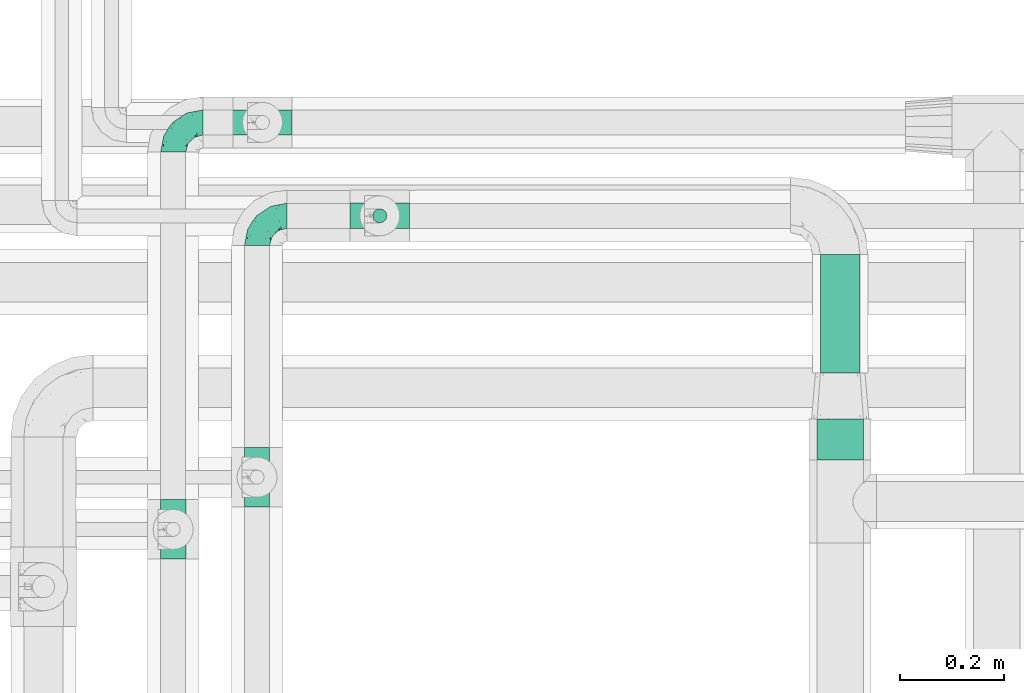
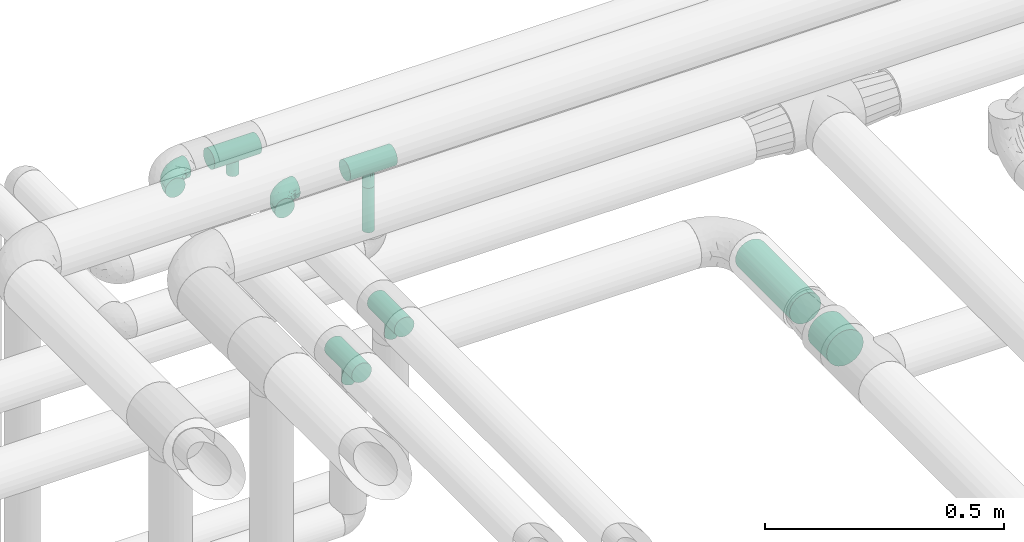
# One storey, part 652 of 827: 6 flow fittings, 3 flow segments.
"""IFC2X3 building model written with IfcOpenShell, lengths in millimetres."""

from ifc_helpers import new_model, entity, si_unit, converted_unit, derived_unit, direction, frame, origin, origin_2d_with_axis, place, context, subcontext, project, spatial, circle, extrude, faceted_brep, source, transform, mapped, material, type_object, type_shapes, element, save


model = new_model("IFC2X3")

# Units and contexts
model_context = context("Model", 3, precision=0.01, world=origin(), true_north=direction((6.12303176911189e-17, 1.0)))
body_context = subcontext(model_context, "Body", "Model", "MODEL_VIEW")
ifc_project = project(units=[si_unit("LENGTHUNIT", "METRE", prefix="MILLI"), si_unit("AREAUNIT", "SQUARE_METRE"), si_unit("VOLUMEUNIT", "CUBIC_METRE"), converted_unit("PLANEANGLEUNIT", "DEGREE", entity("IfcRatioMeasure", 0.0174532925199433), si_unit("PLANEANGLEUNIT", "RADIAN"), dimensions=[0, 0, 0, 0, 0, 0, 0]), si_unit("MASSUNIT", "GRAM", prefix="KILO"), derived_unit("MASSDENSITYUNIT", [(si_unit("MASSUNIT", "GRAM", prefix="KILO"), 1), (si_unit("LENGTHUNIT", "METRE"), -3)]), derived_unit("MOMENTOFINERTIAUNIT", [(si_unit("LENGTHUNIT", "METRE"), 4)]), si_unit("TIMEUNIT", "SECOND"), si_unit("FREQUENCYUNIT", "HERTZ"), si_unit("THERMODYNAMICTEMPERATUREUNIT", "DEGREE_CELSIUS"), derived_unit("THERMALTRANSMITTANCEUNIT", [(si_unit("MASSUNIT", "GRAM", prefix="KILO"), 1), (si_unit("THERMODYNAMICTEMPERATUREUNIT", "KELVIN"), -1), (si_unit("TIMEUNIT", "SECOND"), -3)]), derived_unit("VOLUMETRICFLOWRATEUNIT", [(si_unit("LENGTHUNIT", "METRE"), 3), (si_unit("TIMEUNIT", "SECOND"), -1)]), derived_unit("MASSFLOWRATEUNIT", [(si_unit("MASSUNIT", "GRAM", prefix="KILO"), 1), (si_unit("TIMEUNIT", "SECOND"), -1)]), derived_unit("ROTATIONALFREQUENCYUNIT", [(si_unit("TIMEUNIT", "SECOND"), -1)]), si_unit("ELECTRICCURRENTUNIT", "AMPERE"), si_unit("ELECTRICVOLTAGEUNIT", "VOLT"), si_unit("POWERUNIT", "WATT"), si_unit("FORCEUNIT", "NEWTON", prefix="KILO"), si_unit("ILLUMINANCEUNIT", "LUX"), si_unit("LUMINOUSFLUXUNIT", "LUMEN"), si_unit("LUMINOUSINTENSITYUNIT", "CANDELA"), derived_unit("USERDEFINED", [(si_unit("MASSUNIT", "GRAM", prefix="KILO"), -1), (si_unit("LENGTHUNIT", "METRE"), -2), (si_unit("TIMEUNIT", "SECOND"), 3), (si_unit("LUMINOUSFLUXUNIT", "LUMEN"), 1)]), derived_unit("LINEARVELOCITYUNIT", [(si_unit("LENGTHUNIT", "METRE"), 1), (si_unit("TIMEUNIT", "SECOND"), -1)]), si_unit("PRESSUREUNIT", "PASCAL"), derived_unit("USERDEFINED", [(si_unit("LENGTHUNIT", "METRE"), -2), (si_unit("MASSUNIT", "GRAM", prefix="KILO"), 1), (si_unit("TIMEUNIT", "SECOND"), -2)]), derived_unit("LINEARFORCEUNIT", [(si_unit("MASSUNIT", "GRAM", prefix="KILO"), 1), (si_unit("LENGTHUNIT", "METRE"), 1), (si_unit("TIMEUNIT", "SECOND"), -2), (si_unit("LENGTHUNIT", "METRE"), -1)]), derived_unit("PLANARFORCEUNIT", [(si_unit("MASSUNIT", "GRAM", prefix="KILO"), 1), (si_unit("LENGTHUNIT", "METRE"), 1), (si_unit("TIMEUNIT", "SECOND"), -2), (si_unit("LENGTHUNIT", "METRE"), -2)])], contexts=[model_context])

# Site, building, storey
site_placement = place(None, origin())
site = spatial("IfcSite", under=ifc_project, at=site_placement, CompositionType="ELEMENT")
building_placement = place(site_placement, origin())
building = spatial("IfcBuilding", under=site, at=building_placement, CompositionType="ELEMENT")
storey_placement = place(building_placement, frame((0.0, 0.0, 28200.0)))
storey = spatial("IfcBuildingStorey", under=building, at=storey_placement, Name="08", CompositionType="ELEMENT", Elevation=28200.0)

# Flow segments
pipe_segment_type_1 = type_object("IfcPipeSegmentType", PredefinedType="NOTDEFINED")
flow_segment_1_placement = place(storey_placement, frame((37702.2, 18468.39, 2854.0)))
element("IfcFlowSegment", 1, at=flow_segment_1_placement, inside=storey, type_object=pipe_segment_type_1, context=body_context, shape_type="SweptSolid", body=[
    extrude(circle(Radius=44.5, at=origin_2d_with_axis()), frame((46.1, 0.0, 46.1), z_axis=(4.72442611267921e-07, 1.0, 3.91458552369079e-05), x_axis=(1.0, -4.72442611629906e-07, 0.0)), (0.0, 0.0, 1.0), 77.9033557738992),
])
flow_segment_2_placement = place(storey_placement, frame((37708.7, 18635.29, 2860.49)))
element("IfcFlowSegment", 2, at=flow_segment_2_placement, inside=storey, type_object=pipe_segment_type_1, context=body_context, shape_type="SweptSolid", body=[
    extrude(circle(Radius=38.0, at=origin_2d_with_axis()), frame((39.6, 0.0, 39.6), z_axis=(-5.75712151076748e-07, 1.0, -3.25499104399148e-05), x_axis=(1.0, 5.75712151381731e-07, 0.0)), (0.0, 0.0, 1.0), 226.946471707093),
])
pipe_segment_type_2 = type_object("IfcPipeSegmentType", PredefinedType="NOTDEFINED")
flow_segment_3_placement = place(storey_placement, frame((36850.03, 18921.41, 3229.1)))
element("IfcFlowSegment", 3, at=flow_segment_3_placement, inside=storey, type_object=pipe_segment_type_2, context=body_context, shape_type="SweptSolid", body=[
    extrude(circle(Radius=13.4, at=origin_2d_with_axis()), frame((15.0, 15.0, 0.0)), (0.0, 0.0, 1.0), 113.79066122207),
])

# Flow fittings
ifc_material = material()
pipe_fitting_type_1 = type_object("IfcPipeFittingType", Name="ADSK_1", PredefinedType="NOTDEFINED", material=ifc_material)
shared_shape_1 = source(origin(), body_context, "Body", "Brep", [
    faceted_brep([(-57.0, 12.07, -20.91), (-57.0, 6.25, -23.33), (-57.0, 0.0, -24.15), (-57.0, -6.25, -23.33), (-57.0, -12.08, -20.91), (-57.0, -17.08, -17.08), (-57.0, -20.91, -12.08), (-57.0, -23.33, -6.25), (-57.0, -24.15, 0.0), (-57.0, -23.33, 6.25), (-57.0, -20.91, 12.07), (-57.0, -17.08, 17.08), (-57.0, -12.08, 20.91), (-57.0, -6.25, 23.33), (-57.0, 0.0, 24.15), (-57.0, 6.25, 23.33), (-57.0, 12.07, 20.91), (-57.0, 17.08, 17.08), (-57.0, 20.91, 12.07), (-57.0, 23.33, 6.25), (-57.0, 24.15, 0.0), (-57.0, 23.33, -6.25), (-57.0, 20.91, -12.08), (-57.0, 17.08, -17.08), (0.0, 57.0, -24.15), (-6.25, 57.0, -23.33), (-12.07, 57.0, -20.91), (-17.08, 57.0, -17.08), (-20.91, 57.0, -12.08), (-23.33, 57.0, -6.25), (-24.15, 57.0, 0.0), (-23.33, 57.0, 6.25), (-20.91, 57.0, 12.07), (-17.08, 57.0, 17.08), (-12.07, 57.0, 20.91), (-6.25, 57.0, 23.33), (0.0, 57.0, 24.15), (6.25, 57.0, 23.33), (12.08, 57.0, 20.91), (17.08, 57.0, 17.08), (20.91, 57.0, 12.07), (23.33, 57.0, 6.25), (24.15, 57.0, 0.0), (23.33, 57.0, -6.25), (20.91, 57.0, -12.08), (17.08, 57.0, -17.08), (12.08, 57.0, -20.91), (6.25, 57.0, -23.33), (14.9, 21.14, 6.17), (13.61, 24.64, 12.48), (6.23, 8.95, 8.98), (-41.47, -21.06, 0.0), (-41.92, -18.38, 13.72), (-24.64, -13.61, 12.48), (-37.37, -13.24, 18.15), (-6.8, -4.93, 8.18), (-21.76, -15.19, 6.22), (-12.78, -9.18, 0.0), (-37.73, -20.51, 7.75), (-7.38, 7.38, 20.24), (-23.37, -4.26, 20.42), (-11.9, -3.19, 15.86), (-42.14, -8.7, 21.82), (13.24, 37.37, 18.15), (9.33, 23.53, 16.85), (4.26, 23.37, 20.42), (2.77, 10.92, 15.55), (-29.46, 0.91, 23.52), (-44.13, 20.56, 15.69), (-39.25, 26.33, 10.88), (-49.02, 22.92, 9.96), (-34.58, 23.87, 17.15), (-15.8, 6.8, 22.81), (-8.67, 20.47, 23.88), (-18.12, 12.9, 24.08), (-48.29, 14.92, 19.65), (-44.06, -2.85, 23.78), (-9.23, 48.95, 22.58), (-3.78, 42.74, 24.07), (-40.34, 4.26, 24.09), (-44.02, 26.14, 5.46), (-44.04, 9.88, 22.74), (-4.95, 16.87, 22.52), (-2.75, 1.43, 12.5), (-25.48, 40.98, 10.71), (20.51, 37.73, 7.75), (18.38, 41.92, 13.72), (8.7, 42.14, 21.82), (-25.95, -17.97, 0.0), (2.85, 44.06, 23.78), (21.06, 41.47, 0.0), (17.97, 25.95, 0.0), (-24.04, -9.27, 17.13), (-33.26, 33.26, 5.86), (-28.55, 40.57, 0.0), (-40.57, 28.55, 0.0), (-25.29, 47.19, 4.06), (-27.01, 31.1, 16.77), (-15.7, 43.95, 19.9), (-20.27, 45.22, 15.61), (-30.53, 31.98, 12.64), (-11.28, 38.33, 22.92), (-9.97, 27.88, 24.09), (-20.15, 30.26, 21.25), (-31.25, 11.75, 23.64), (-28.75, 7.23, 24.15), (-29.53, 18.06, 22.27), (-28.44, 24.21, 20.02), (-37.55, 17.7, 20.26), (-15.88, 29.25, 22.99), (-20.82, 20.82, 23.44), (-0.91, 29.46, 23.52), (-13.5, -7.67, 12.04), (1.49, 1.56, 5.16), (8.86, 10.35, 4.59), (0.38, -0.38, 0.0), (9.18, 12.78, 0.0), (-37.37, -13.24, -18.15), (8.86, 10.35, -4.59), (-45.22, 20.27, -15.61), (-43.95, 15.7, -19.9), (-38.33, 11.28, -22.92), (-48.95, 9.23, -22.58), (-47.19, 25.29, -4.06), (-33.26, 33.26, -5.86), (18.38, 41.92, -13.72), (-30.26, 20.15, -21.25), (2.85, 44.06, -23.78), (-4.26, 40.34, -24.09), (-40.98, 25.48, -10.71), (-41.92, -18.38, -13.72), (9.25, 23.5, -16.92), (4.26, 23.37, -20.42), (13.24, 37.37, -18.15), (-37.73, -20.51, -7.75), (-11.75, 31.25, -23.64), (-7.23, 28.75, -24.15), (-12.9, 18.12, -24.08), (8.7, 42.14, -21.82), (-44.06, -2.85, -23.78), (-6.8, 15.8, -22.81), (-20.47, 8.67, -23.88), (-24.64, -13.61, -12.48), (-42.74, 3.78, -24.07), (-18.06, 29.53, -22.27), (-24.21, 28.44, -20.02), (-27.88, 9.97, -24.09), (-31.1, 27.01, -16.77), (-26.14, 44.02, -5.46), (14.9, 21.14, -6.17), (20.51, 37.73, -7.75), (-9.88, 44.04, -22.74), (-20.56, 44.13, -15.69), (-21.76, -15.19, -6.22), (-13.5, -7.67, -12.04), (-24.14, -9.76, -16.74), (-11.9, -3.19, -15.86), (-14.92, 48.29, -19.65), (-23.37, -4.26, -20.42), (-0.91, 29.46, -23.52), (-26.33, 39.25, -10.88), (-23.87, 34.58, -17.15), (-42.14, -8.7, -21.82), (-22.92, 49.02, -9.96), (13.61, 24.64, -12.48), (-31.98, 30.53, -12.64), (-16.87, 4.95, -22.52), (-17.7, 37.55, -20.26), (-29.25, 15.88, -22.99), (-20.82, 20.82, -23.44), (-29.46, 0.91, -23.52), (-7.38, 7.38, -20.24), (2.77, 10.92, -15.55), (6.23, 8.95, -8.98), (-6.8, -4.93, -8.18), (-2.81, 1.41, -12.54), (1.49, 1.56, -5.16)], [[[0, 1, 2, 3, 4, 5, 6, 7, 8, 9, 10, 11, 12, 13, 14, 15, 16, 17, 18, 19, 20, 21, 22, 23]], [[24, 25, 26, 27, 28, 29, 30, 31, 32, 33, 34, 35, 36, 37, 38, 39, 40, 41, 42, 43, 44, 45, 46, 47]], [[48, 49, 50]], [[9, 8, 51]], [[52, 53, 54]], [[55, 56, 57]], [[10, 58, 52]], [[9, 58, 10]], [[59, 60, 61]], [[54, 12, 11]], [[54, 62, 12]], [[63, 39, 38]], [[64, 65, 66]], [[62, 60, 67]], [[68, 69, 70]], [[71, 69, 68]], [[72, 73, 74]], [[16, 75, 17]], [[13, 76, 14]], [[35, 77, 78]], [[14, 79, 15]], [[17, 68, 18]], [[14, 76, 79]], [[20, 19, 80]], [[70, 19, 18]], [[81, 15, 79]], [[15, 81, 16]], [[73, 72, 82]], [[66, 83, 50]], [[32, 31, 84]], [[85, 86, 49]], [[63, 87, 65]], [[56, 58, 88]], [[36, 89, 37]], [[85, 41, 40]], [[36, 35, 78]], [[90, 41, 85]], [[40, 39, 86]], [[12, 62, 13]], [[86, 85, 40]], [[48, 85, 49]], [[85, 91, 90]], [[87, 38, 37]], [[92, 60, 54]], [[80, 69, 93]], [[93, 94, 95]], [[10, 52, 11]], [[94, 96, 30]], [[97, 98, 99]], [[80, 93, 95]], [[100, 97, 84]], [[99, 98, 33]], [[101, 102, 78]], [[103, 101, 98]], [[96, 31, 30]], [[77, 98, 101]], [[77, 35, 34]], [[34, 33, 98]], [[9, 51, 58]], [[87, 63, 38]], [[104, 105, 74]], [[106, 103, 107]], [[106, 81, 104]], [[75, 68, 17]], [[108, 107, 71]], [[33, 32, 99]], [[109, 103, 110]], [[101, 109, 102]], [[89, 78, 111]], [[53, 52, 58]], [[54, 11, 52]], [[60, 62, 54]], [[88, 58, 51]], [[76, 62, 67]], [[53, 112, 92]], [[60, 59, 72]], [[39, 63, 86]], [[49, 86, 63]], [[89, 87, 37]], [[42, 41, 90]], [[111, 82, 65]], [[111, 65, 87]], [[65, 59, 66]], [[104, 81, 79]], [[75, 81, 108]], [[32, 84, 99]], [[97, 99, 84]], [[98, 97, 103]], [[106, 107, 108]], [[74, 102, 110]], [[111, 78, 102]], [[74, 110, 104]], [[74, 67, 72]], [[61, 92, 112]], [[66, 59, 61]], [[56, 53, 58]], [[66, 50, 49]], [[61, 112, 83]], [[66, 49, 64]], [[78, 89, 36]], [[87, 89, 111]], [[62, 76, 13]], [[79, 76, 67]], [[100, 93, 69]], [[96, 93, 84]], [[55, 113, 50]], [[113, 114, 50]], [[104, 79, 105]], [[106, 104, 110]], [[20, 80, 95]], [[85, 48, 91]], [[115, 114, 113]], [[116, 91, 48]], [[70, 80, 19]], [[93, 96, 94]], [[84, 31, 96]], [[103, 106, 110]], [[81, 106, 108]], [[103, 97, 107]], [[71, 107, 97]], [[71, 97, 100]], [[108, 71, 68]], [[79, 67, 105]], [[67, 74, 105]], [[115, 113, 57]], [[112, 56, 55]], [[56, 88, 57]], [[60, 72, 67]], [[82, 72, 59]], [[65, 82, 59]], [[82, 111, 73]], [[111, 102, 73]], [[102, 74, 73]], [[81, 75, 16]], [[68, 75, 108]], [[68, 70, 18]], [[80, 70, 69]], [[98, 77, 34]], [[78, 77, 101]], [[93, 100, 84]], [[71, 100, 69]], [[102, 109, 110]], [[101, 103, 109]], [[53, 92, 54]], [[61, 60, 92]], [[56, 112, 53]], [[83, 112, 55]], [[50, 83, 55]], [[61, 83, 66]], [[49, 63, 64]], [[65, 64, 63]], [[57, 113, 55]], [[114, 115, 116]], [[116, 48, 114]], [[48, 50, 114]], [[117, 5, 4]], [[116, 115, 118]], [[119, 120, 23]], [[121, 122, 120]], [[95, 123, 20]], [[0, 23, 120]], [[124, 95, 94]], [[125, 45, 44]], [[121, 120, 126]], [[24, 127, 128]], [[22, 21, 129]], [[0, 122, 1]], [[5, 117, 130]], [[131, 132, 133]], [[134, 88, 51]], [[135, 136, 137]], [[6, 5, 130]], [[46, 138, 47]], [[139, 3, 2]], [[140, 141, 137]], [[6, 134, 7]], [[134, 130, 142]], [[143, 2, 1]], [[144, 126, 145]], [[121, 146, 143]], [[147, 120, 119]], [[94, 148, 124]], [[149, 150, 91]], [[30, 29, 148]], [[151, 25, 128]], [[27, 152, 28]], [[134, 153, 88]], [[154, 155, 156]], [[27, 26, 157]], [[151, 26, 25]], [[155, 158, 156]], [[24, 47, 127]], [[1, 122, 143]], [[138, 132, 159]], [[160, 152, 161]], [[24, 128, 25]], [[46, 133, 138]], [[162, 117, 4]], [[148, 160, 124]], [[152, 160, 163]], [[154, 142, 155]], [[45, 125, 133]], [[133, 46, 45]], [[125, 164, 133]], [[51, 7, 134]], [[42, 90, 43]], [[165, 147, 129]], [[153, 134, 142]], [[43, 150, 44]], [[162, 4, 3]], [[141, 140, 166]], [[117, 162, 158]], [[163, 29, 28]], [[43, 90, 150]], [[123, 21, 20]], [[144, 151, 135]], [[157, 152, 27]], [[167, 145, 161]], [[23, 22, 119]], [[168, 126, 169]], [[121, 168, 146]], [[139, 143, 170]], [[142, 130, 117]], [[8, 7, 51]], [[134, 6, 130]], [[139, 162, 3]], [[170, 166, 158]], [[170, 158, 162]], [[158, 171, 156]], [[44, 150, 125]], [[91, 150, 90]], [[164, 125, 150]], [[132, 138, 133]], [[127, 138, 159]], [[131, 164, 172]], [[132, 171, 140]], [[135, 151, 128]], [[157, 151, 167]], [[22, 129, 119]], [[147, 119, 129]], [[120, 147, 126]], [[144, 145, 167]], [[137, 146, 169]], [[170, 143, 146]], [[137, 169, 135]], [[137, 159, 140]], [[171, 172, 156]], [[173, 174, 175]], [[156, 175, 154]], [[174, 57, 153]], [[132, 172, 171]], [[172, 164, 173]], [[143, 139, 2]], [[162, 139, 170]], [[138, 127, 47]], [[128, 127, 159]], [[165, 124, 160]], [[123, 124, 129]], [[149, 173, 164]], [[176, 174, 173]], [[135, 128, 136]], [[144, 135, 169]], [[150, 149, 164]], [[176, 118, 115]], [[149, 91, 116]], [[30, 148, 94]], [[163, 148, 29]], [[124, 123, 95]], [[129, 21, 123]], [[126, 144, 169]], [[151, 144, 167]], [[126, 147, 145]], [[161, 145, 147]], [[161, 147, 165]], [[167, 161, 152]], [[128, 159, 136]], [[159, 137, 136]], [[154, 153, 142]], [[132, 140, 159]], [[174, 176, 57]], [[57, 88, 153]], [[166, 140, 171]], [[158, 166, 171]], [[166, 170, 141]], [[170, 146, 141]], [[146, 137, 141]], [[151, 157, 26]], [[152, 157, 167]], [[152, 163, 28]], [[148, 163, 160]], [[120, 122, 0]], [[143, 122, 121]], [[124, 165, 129]], [[161, 165, 160]], [[146, 168, 169]], [[121, 126, 168]], [[142, 117, 155]], [[158, 155, 117]], [[175, 156, 172]], [[153, 154, 174]], [[173, 175, 172]], [[174, 154, 175]], [[164, 131, 133]], [[172, 132, 131]], [[176, 173, 118]], [[57, 176, 115]], [[173, 149, 118]], [[149, 116, 118]]]),
])
type_shapes(pipe_fitting_type_1, [shared_shape_1])
for number, where, z_axis, x_axis, name in (
    (4, (36468.72, 19115.49, 3399.89), (0.0, 0.0, 1.0), (-1.0, 0.0, 0.0), "ADSK_1"),
    (5, (36629.64, 18936.4, 3399.89), (0.0, 0.0, 1.0), (-1.0, 0.0, 0.0), "ADSK_1"),
):
    element("IfcFlowFitting", number, at=place(storey_placement, frame(where, z_axis=z_axis, x_axis=x_axis)), inside=storey, type_object=pipe_fitting_type_1, material=ifc_material, Name=name, ObjectType="ADSK_1", context=body_context, shape_type="MappedRepresentation", body=[
        mapped(shared_shape_1, transform((0.0, 0.0, 0.0), scale=1.0)),
    ])
pipe_fitting_type_2 = type_object("IfcPipeFittingType", Name="ADSK_1", PredefinedType="NOTDEFINED", material=ifc_material)
shared_shape_2 = source(origin(), body_context, "Body", "Brep", [
    faceted_brep([(-57.0, 12.07, -20.91), (-57.0, 6.25, -23.33), (-57.0, 0.0, -24.15), (-57.0, -6.25, -23.33), (-57.0, -12.08, -20.91), (-57.0, -17.08, -17.08), (-57.0, -20.91, -12.08), (-57.0, -23.33, -6.25), (-57.0, -24.15, 0.0), (-57.0, -23.33, 6.25), (-57.0, -20.91, 12.07), (-57.0, -17.08, 17.08), (-57.0, -12.08, 20.91), (-57.0, -6.25, 23.33), (-57.0, 0.0, 24.15), (-57.0, 6.25, 23.33), (-57.0, 12.07, 20.91), (-57.0, 17.08, 17.08), (-57.0, 20.91, 12.07), (-57.0, 23.33, 6.25), (-57.0, 24.15, 0.0), (-57.0, 23.33, -6.25), (-57.0, 20.91, -12.08), (-57.0, 17.08, -17.08), (57.0, 0.0, -24.15), (57.0, 6.25, -23.33), (57.0, 12.07, -20.91), (57.0, 17.08, -17.08), (57.0, 20.91, -12.08), (57.0, 23.33, -6.25), (57.0, 24.15, 0.0), (57.0, 23.33, 6.25), (57.0, 20.91, 12.07), (57.0, 17.08, 17.08), (57.0, 12.07, 20.91), (57.0, 6.25, 23.33), (57.0, 0.0, 24.15), (57.0, -6.25, 23.33), (57.0, -12.08, 20.91), (57.0, -17.08, 17.08), (57.0, -20.91, 12.07), (57.0, -23.33, 6.25), (57.0, -24.15, 0.0), (57.0, -23.33, -6.25), (57.0, -20.91, -12.08), (57.0, -17.08, -17.08), (57.0, -12.08, -20.91), (57.0, -6.25, -23.33), (12.61, -23.69, 4.67), (13.03, -23.92, 2.34), (13.45, -24.15, 0.0), (10.28, -22.54, 8.68), (2.38, -20.2, 13.24), (6.77, -21.17, 11.62), (4.58, -20.68, 12.43), (-13.45, -24.15, 0.0), (-13.03, -23.92, 2.34), (-12.61, -23.69, 4.67), (-10.28, -22.54, 8.67), (-6.77, -21.17, 11.62), (-4.58, -20.68, 12.43), (-2.38, -20.2, 13.24), (0.0, -20.2, 13.24), (2.38, -20.2, -13.24), (6.77, -21.17, -11.62), (4.58, -20.68, -12.43), (10.28, -22.54, -8.68), (12.61, -23.69, -4.67), (13.03, -23.92, -2.34), (-2.38, -20.2, -13.24), (-4.58, -20.68, -12.43), (-6.77, -21.17, -11.62), (-10.28, -22.54, -8.67), (0.0, -20.2, -13.24), (-12.61, -23.69, -4.67), (-13.03, -23.92, -2.34), (-12.99, -57.0, -3.48), (-11.65, -57.0, -6.73), (-9.51, -57.0, -9.51), (-6.72, -57.0, -11.65), (-3.48, -57.0, -12.99), (0.0, -57.0, -13.45), (3.48, -57.0, -12.99), (6.73, -57.0, -11.65), (9.51, -57.0, -9.51), (11.65, -57.0, -6.73), (12.99, -57.0, -3.48), (13.45, -57.0, 0.0), (12.99, -57.0, 3.48), (11.65, -57.0, 6.72), (9.51, -57.0, 9.51), (6.73, -57.0, 11.65), (3.48, -57.0, 12.99), (0.0, -57.0, 13.45), (-3.48, -57.0, 12.99), (-6.72, -57.0, 11.65), (-9.51, -57.0, 9.51), (-11.65, -57.0, 6.72), (-12.99, -57.0, 3.48), (-13.45, -57.0, 0.0)], [[[0, 1, 2, 3, 4, 5, 6, 7, 8, 9, 10, 11, 12, 13, 14, 15, 16, 17, 18, 19, 20, 21, 22, 23]], [[24, 25, 26, 27, 28, 29, 30, 31, 32, 33, 34, 35, 36, 37, 38, 39, 40, 41, 42, 43, 44, 45, 46, 47]], [[42, 41, 48]], [[42, 48, 49, 50]], [[41, 51, 48]], [[40, 39, 52]], [[53, 51, 40]], [[40, 52, 54, 53]], [[39, 11, 52]], [[40, 51, 41]], [[8, 55, 56, 57]], [[9, 8, 57]], [[57, 58, 9]], [[10, 59, 60, 61]], [[59, 10, 58]], [[10, 61, 11]], [[58, 10, 9]], [[11, 61, 62, 52]], [[39, 38, 12, 11]], [[14, 13, 37, 36]], [[13, 12, 38, 37]], [[15, 14, 36, 35]], [[32, 31, 19, 18]], [[17, 16, 34, 33]], [[18, 17, 33, 32]], [[35, 34, 16, 15]], [[20, 19, 31, 30]], [[29, 28, 22, 21]], [[28, 27, 23, 22]], [[30, 29, 21, 20]], [[24, 47, 3, 2]], [[1, 0, 26, 25]], [[2, 1, 25, 24]], [[27, 26, 0, 23]], [[4, 3, 47, 46]], [[46, 45, 5, 4]], [[45, 44, 63]], [[44, 64, 65, 63]], [[44, 66, 64]], [[45, 63, 5]], [[43, 42, 67]], [[67, 66, 43]], [[42, 50, 68, 67]], [[43, 66, 44]], [[6, 69, 70, 71]], [[6, 5, 69]], [[71, 72, 6]], [[5, 63, 73, 69]], [[72, 74, 7]], [[74, 8, 7]], [[8, 74, 75, 55]], [[72, 7, 6]], [[76, 77, 78, 79, 80, 81, 82, 83, 84, 85, 86, 87, 88, 89, 90, 91, 92, 93, 94, 95, 96, 97, 98, 99]], [[57, 98, 97]], [[59, 96, 95]], [[97, 96, 58]], [[91, 54, 92]], [[56, 99, 98]], [[55, 99, 56]], [[98, 57, 56]], [[58, 57, 97]], [[96, 59, 58]], [[49, 48, 88]], [[60, 59, 95]], [[94, 61, 60]], [[49, 87, 50]], [[93, 52, 62, 61]], [[91, 53, 54]], [[90, 53, 91]], [[48, 89, 88]], [[90, 89, 51]], [[52, 93, 92]], [[54, 52, 92]], [[60, 95, 94]], [[53, 90, 51]], [[51, 89, 48]], [[93, 61, 94]], [[87, 49, 88]], [[86, 68, 87]], [[81, 63, 82]], [[65, 83, 82]], [[65, 64, 83]], [[86, 67, 68]], [[67, 86, 85]], [[75, 74, 76]], [[66, 85, 84]], [[68, 50, 87]], [[67, 85, 66]], [[79, 70, 80]], [[64, 66, 84]], [[82, 63, 65]], [[64, 84, 83]], [[81, 69, 73, 63]], [[79, 71, 70]], [[78, 71, 79]], [[74, 77, 76]], [[78, 77, 72]], [[69, 81, 80]], [[70, 69, 80]], [[71, 78, 72]], [[72, 77, 74]], [[99, 75, 76]], [[75, 99, 55]]]),
])
type_shapes(pipe_fitting_type_2, [shared_shape_2])
for number, where, z_axis, x_axis, name in (
    (6, (36865.02, 18936.4, 3399.89), (0.0, 1.0, 0.0), (-1.0, 0.0, 0.0), "ADSK_1"),
    (7, (36640.02, 19115.49, 3399.89), (0.0, -1.0, 0.0), (1.0, 0.0, 0.0), "ADSK_1"),
    (8, (36468.72, 18334.91, 3399.89), (1.0, 0.0, 0.0), (0.0, 1.0, 0.0), "ADSK_1"),
    (9, (36629.64, 18434.91, 3399.89), (1.0, 0.0, 0.0), (0.0, 1.0, 0.0), "ADSK_1"),
):
    element("IfcFlowFitting", number, at=place(storey_placement, frame(where, z_axis=z_axis, x_axis=x_axis)), inside=storey, type_object=pipe_fitting_type_2, material=ifc_material, Name=name, ObjectType="ADSK_1", context=body_context, shape_type="MappedRepresentation", body=[
        mapped(shared_shape_2, transform((0.0, 0.0, 0.0), scale=1.0)),
    ])

save(model, "model.ifc")
